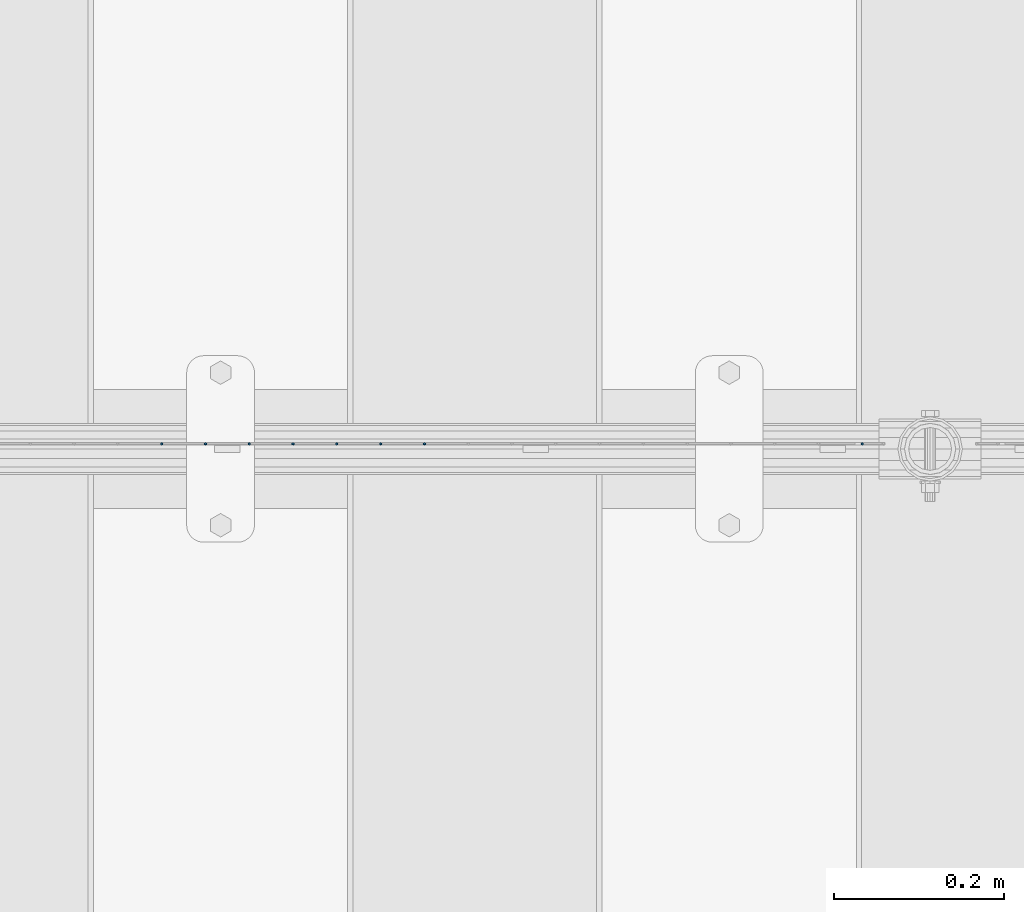
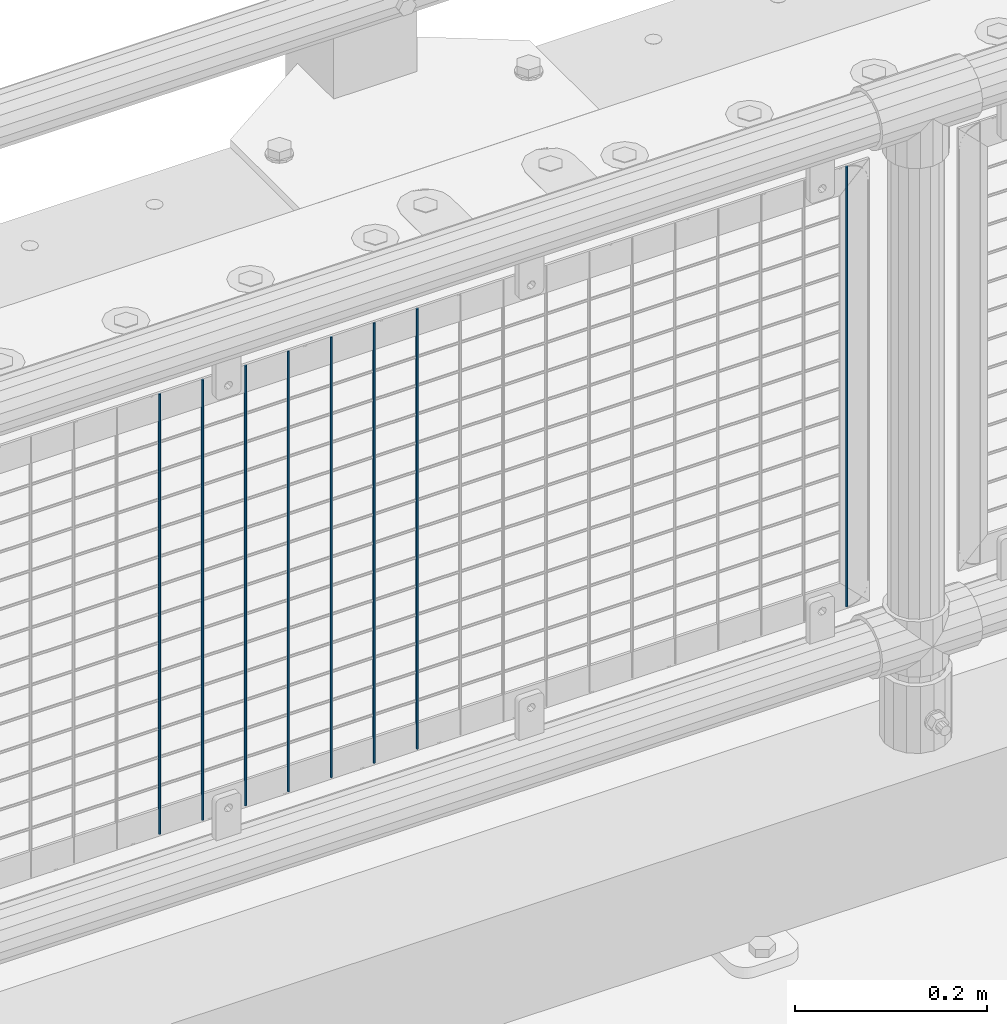
# One storey, part 59 of 193: 8 columns.
"""IFC2X3 building model written with IfcOpenShell, lengths in millimetres."""

from ifc_helpers import new_model, si_unit, frame, origin_with_axes, place, context, subcontext, project, spatial, faceted_brep, material, type_object, element, save


model = new_model("IFC2X3")

# Units and contexts
model_context = context("Model", 3, precision=1e-05, world=origin_with_axes())
body_context = subcontext(model_context, "Body", "Model", "MODEL_VIEW")
ifc_project = project(units=[si_unit("LENGTHUNIT", "METRE", prefix="MILLI"), si_unit("AREAUNIT", "SQUARE_METRE"), si_unit("VOLUMEUNIT", "CUBIC_METRE"), si_unit("MASSUNIT", "GRAM", prefix="KILO"), si_unit("TIMEUNIT", "SECOND"), si_unit("PLANEANGLEUNIT", "RADIAN"), si_unit("SOLIDANGLEUNIT", "STERADIAN"), si_unit("THERMODYNAMICTEMPERATUREUNIT", "DEGREE_CELSIUS"), si_unit("LUMINOUSINTENSITYUNIT", "LUMEN")], contexts=[model_context])

# Site, building, storey
site_placement = place(None, origin_with_axes())
site = spatial("IfcSite", under=ifc_project, at=site_placement, CompositionType="ELEMENT")
building_placement = place(site_placement, origin_with_axes())
building = spatial("IfcBuilding", under=site, at=building_placement, Name="Standard", CompositionType="ELEMENT")
storey_placement = place(building_placement, origin_with_axes())
storey = spatial("IfcBuildingStorey", under=building, at=storey_placement, Name="Undefined", CompositionType="ELEMENT", Elevation=0.0)

# Columns
ifc_material = material(Name="Misc_Undefined")
column_type = type_object("IfcColumnType", Name="D3", PredefinedType="NOTDEFINED")
for number, where, z_axis, x_axis in (
    (1, (-39109.555, 28670.5, 353.02), (-1.0, 0.0, 0.0), (0.0, 0.0, 1.0)),
    (2, (-39161.21, 28670.5, 353.02), (-1.0, 0.0, 0.0), (0.0, 0.0, 1.0)),
    (3, (-39212.865, 28670.5, 353.02), (-1.0, 0.0, 0.0), (0.0, 0.0, 1.0)),
    (4, (-39264.52, 28670.5, 353.02), (-1.0, 0.0, 0.0), (0.0, 0.0, 1.0)),
    (5, (-39316.175, 28670.5, 353.02), (-1.0, 0.0, 0.0), (0.0, 0.0, 1.0)),
    (6, (-39367.83, 28670.5, 353.02), (-1.0, 0.0, 0.0), (0.0, 0.0, 1.0)),
    (7, (-39419.485, 28670.5, 353.02), (-1.0, 0.0, 0.0), (0.0, 0.0, 1.0)),
    (8, (-38593.005, 28670.5, 353.02), (-1.0, 0.0, 0.0), (0.0, 0.0, 1.0)),
):
    element("IfcColumn", number, at=place(storey_placement, frame(where, z_axis=z_axis, x_axis=x_axis)), inside=storey, type_object=column_type, material=ifc_material, ObjectType="D3", context=body_context, shape_type="Brep", body=[
        faceted_brep([(0.0, -1.49999999999636, 3.63797880709171e-12), (0.0, -0.75, -1.29903810567669), (560.0, -0.75, -1.29903810567703), (560.0, -1.5, 0.0), (0.0, 0.75, -1.29903810567669), (560.0, 0.75, -1.29903810567703), (0.0, 1.50000000000364, 7.27595761418343e-12), (560.0, 1.5, 0.0), (0.0, 0.75, 1.29903810567669), (560.0, 0.75, 1.29903810567703), (0.0, -0.75, 1.29903810567669), (560.0, -0.75, 1.29903810567703)], [[[0, 1, 2, 3]], [[1, 4, 5, 2]], [[4, 6, 7, 5]], [[6, 8, 9, 7]], [[8, 10, 11, 9]], [[10, 0, 3, 11]], [[5, 7, 9, 11, 3, 2]], [[10, 8, 6, 4, 1, 0]]]),
    ])

save(model, "model.ifc")
